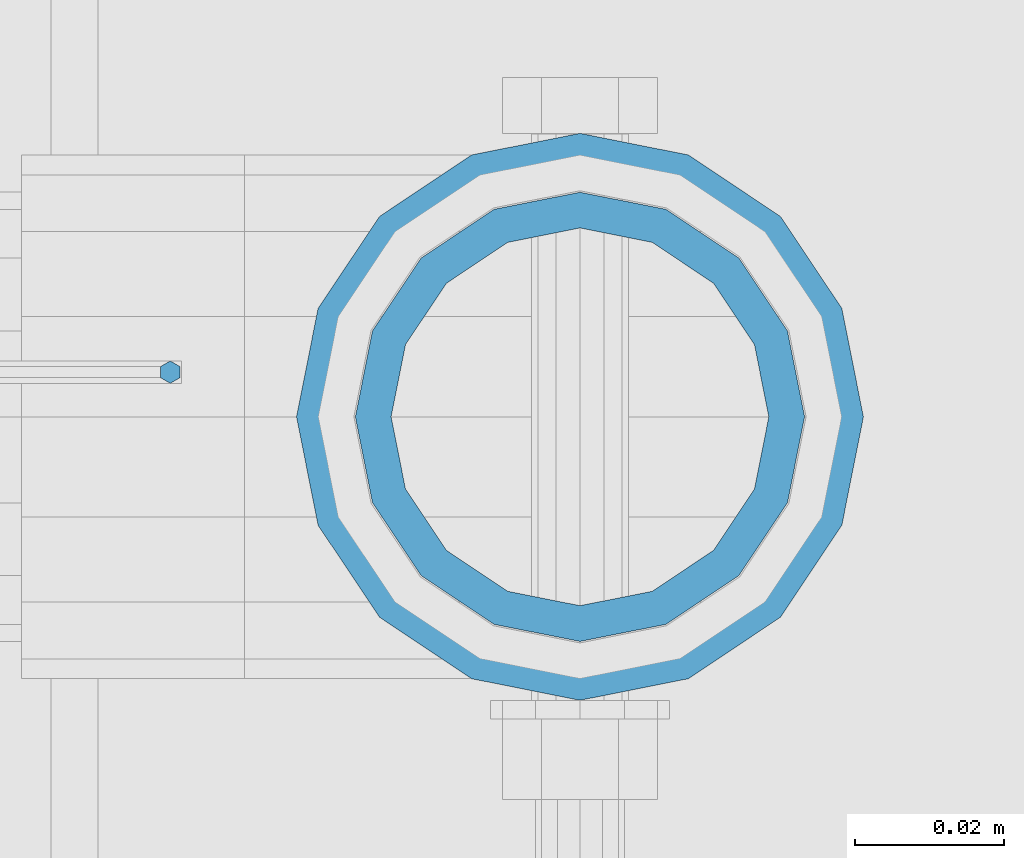
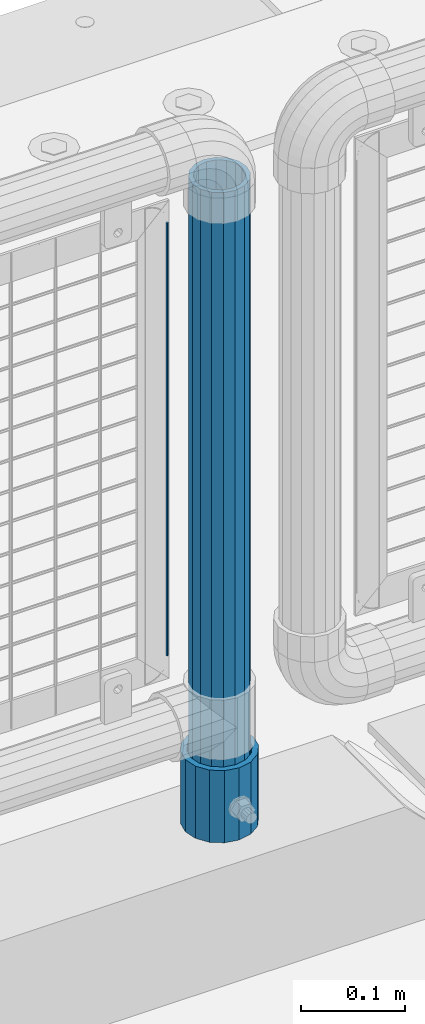
# One storey, part 85 of 208: 3 columns.
"""IFC2X3 building model written with IfcOpenShell, lengths in millimetres."""

from ifc_helpers import new_model, si_unit, frame, origin_with_axes, place, context, subcontext, project, spatial, faceted_brep, material, type_object, element, save


model = new_model("IFC2X3")

# Units and contexts
model_context = context("Model", 3, precision=1e-05, world=origin_with_axes())
body_context = subcontext(model_context, "Body", "Model", "MODEL_VIEW")
ifc_project = project(units=[si_unit("LENGTHUNIT", "METRE", prefix="MILLI"), si_unit("AREAUNIT", "SQUARE_METRE"), si_unit("VOLUMEUNIT", "CUBIC_METRE"), si_unit("MASSUNIT", "GRAM", prefix="KILO"), si_unit("TIMEUNIT", "SECOND"), si_unit("PLANEANGLEUNIT", "RADIAN"), si_unit("SOLIDANGLEUNIT", "STERADIAN"), si_unit("THERMODYNAMICTEMPERATUREUNIT", "DEGREE_CELSIUS"), si_unit("LUMINOUSINTENSITYUNIT", "LUMEN")], contexts=[model_context])

# Site, building, storey
site_placement = place(None, origin_with_axes())
site = spatial("IfcSite", under=ifc_project, at=site_placement, CompositionType="ELEMENT")
building_placement = place(site_placement, origin_with_axes())
building = spatial("IfcBuilding", under=site, at=building_placement, Name="Standard", CompositionType="ELEMENT")
storey_placement = place(building_placement, origin_with_axes())
storey = spatial("IfcBuildingStorey", under=building, at=storey_placement, Name="Undefined", CompositionType="ELEMENT", Elevation=0.0)

# Columns
ifc_material_1 = material()
column_type_1 = type_object("IfcColumnType", PredefinedType="NOTDEFINED")
column_1_placement = place(storey_placement, frame((-27429.0000001958, 4664.5, 168.019999999998), z_axis=(0.0, 1.0, 0.0), x_axis=(0.0, 0.0, 1.0)))
element("IfcColumn", 1, at=column_1_placement, inside=storey, type_object=column_type_1, material=ifc_material_1, context=body_context, shape_type="Brep", body=[
    faceted_brep([(0.0, -31.75, 0.0), (0.0, -29.3331751572332, 12.1501989775916), (85.0, -29.3331751572332, 12.1501989775916), (85.0, -31.75, 0.0), (0.0, -22.4506403026717, 22.4506403026726), (85.0, -22.4506403026717, 22.4506403026726), (0.0, -12.1501989775934, 29.3331751572332), (85.0, -12.1501989775934, 29.3331751572332), (0.0, 0.0, 31.75), (85.0, 0.0, 31.75), (0.0, 12.1501989775934, 29.3331751572332), (85.0, 12.1501989775934, 29.3331751572332), (0.0, 22.4506403026717, 22.4506403026726), (85.0, 22.4506403026717, 22.4506403026726), (0.0, 29.3331751572332, 12.1501989775916), (85.0, 29.3331751572332, 12.1501989775916), (0.0, 31.75, 0.0), (85.0, 31.75, 0.0), (0.0, 29.3331751572332, -12.1501989775916), (85.0, 29.3331751572332, -12.1501989775916), (0.0, 22.4506403026717, -22.4506403026726), (85.0, 22.4506403026717, -22.4506403026726), (0.0, 12.1501989775934, -29.3331751572332), (85.0, 12.1501989775934, -29.3331751572332), (0.0, 0.0, -31.75), (85.0, 0.0, -31.75), (0.0, -12.1501989775934, -29.3331751572332), (85.0, -12.1501989775934, -29.3331751572332), (0.0, -22.4506403026717, -22.4506403026726), (85.0, -22.4506403026717, -22.4506403026726), (0.0, -29.3331751572332, -12.1501989775916), (85.0, -29.3331751572332, -12.1501989775916), (0.0, -38.0499999999993, 0.0), (0.0, -35.1536162120537, -14.5611046014919), (85.0, -35.1536162120537, -14.5611046014919), (85.0, -38.0499999999993, 0.0), (0.0, -26.9054130241493, -26.9054130241484), (85.0, -26.9054130241493, -26.9054130241484), (0.0, -14.5611046014928, -35.1536162120547), (85.0, -14.5611046014928, -35.1536162120547), (0.0, 0.0, -38.0500000000002), (85.0, 0.0, -38.0500000000002), (0.0, 14.5611046014928, -35.1536162120547), (85.0, 14.5611046014928, -35.1536162120547), (0.0, 26.9054130241493, -26.9054130241484), (85.0, 26.9054130241493, -26.9054130241484), (0.0, 35.1536162120537, -14.5611046014919), (85.0, 35.1536162120537, -14.5611046014919), (0.0, 38.0499999999993, 0.0), (85.0, 38.0499999999993, 0.0), (0.0, 35.1536162120537, 14.5611046014919), (85.0, 35.1536162120537, 14.5611046014919), (0.0, 26.9054130241493, 26.9054130241484), (85.0, 26.9054130241493, 26.9054130241484), (0.0, 14.5611046014928, 35.1536162120547), (85.0, 14.5611046014928, 35.1536162120547), (0.0, 0.0, 38.0500000000002), (85.0, 0.0, 38.0500000000002), (0.0, -14.5611046014928, 35.1536162120547), (85.0, -14.5611046014928, 35.1536162120547), (0.0, -26.9054130241493, 26.9054130241484), (85.0, -26.9054130241493, 26.9054130241484), (0.0, -35.1536162120537, 14.5611046014919), (85.0, -35.1536162120537, 14.5611046014919)], [[[0, 1, 2, 3]], [[1, 4, 5, 2]], [[4, 6, 7, 5]], [[6, 8, 9, 7]], [[8, 10, 11, 9]], [[10, 12, 13, 11]], [[12, 14, 15, 13]], [[14, 16, 17, 15]], [[16, 18, 19, 17]], [[18, 20, 21, 19]], [[20, 22, 23, 21]], [[22, 24, 25, 23]], [[24, 26, 27, 25]], [[26, 28, 29, 27]], [[28, 30, 31, 29]], [[30, 0, 3, 31]], [[32, 33, 34, 35]], [[33, 36, 37, 34]], [[36, 38, 39, 37]], [[38, 40, 41, 39]], [[40, 42, 43, 41]], [[42, 44, 45, 43]], [[44, 46, 47, 45]], [[46, 48, 49, 47]], [[48, 50, 51, 49]], [[50, 52, 53, 51]], [[52, 54, 55, 53]], [[54, 56, 57, 55]], [[56, 58, 59, 57]], [[58, 60, 61, 59]], [[60, 62, 63, 61]], [[62, 32, 35, 63]], [[37, 39, 41, 43, 45, 47, 49, 51, 53, 55, 57, 59, 61, 63, 35, 34], [5, 7, 9, 11, 13, 15, 17, 19, 21, 23, 25, 27, 29, 31, 3, 2]], [[62, 60, 58, 56, 54, 52, 50, 48, 46, 44, 42, 40, 38, 36, 33, 32], [30, 28, 26, 24, 22, 20, 18, 16, 14, 12, 10, 8, 6, 4, 1, 0]]]),
])
column_type_2 = type_object("IfcColumnType", PredefinedType="NOTDEFINED")
column_2_placement = place(storey_placement, frame((-27429.0000001958, 4664.5, 168.019999999998), z_axis=(-1.0, 0.0, 0.0), x_axis=(0.0, 0.0, 1.0)))
element("IfcColumn", 2, at=column_2_placement, inside=storey, type_object=column_type_2, material=ifc_material_1, context=body_context, shape_type="Brep", body=[
    faceted_brep([(0.0, -25.3500000000004, 0.0), (0.0, -23.4203461491616, 9.70102501045403), (760.0, -23.4203461491616, 9.70102501045403), (760.0, -25.3500000000004, 0.0), (0.0, -17.9251569030794, 17.9251569030785), (760.0, -17.9251569030794, 17.9251569030785), (0.0, -9.70102501045494, 23.4203461491597), (760.0, -9.70102501045494, 23.4203461491597), (0.0, 0.0, 25.3499999999985), (760.0, 0.0, 25.3499999999985), (0.0, 9.70102501045494, 23.4203461491597), (760.0, 9.70102501045494, 23.4203461491597), (0.0, 17.9251569030794, 17.9251569030785), (760.0, 17.9251569030794, 17.9251569030785), (0.0, 23.4203461491616, 9.70102501045403), (760.0, 23.4203461491616, 9.70102501045403), (0.0, 25.3500000000004, 0.0), (760.0, 25.3500000000004, 0.0), (0.0, 23.4203461491616, -9.70102501045403), (760.0, 23.4203461491616, -9.70102501045403), (0.0, 17.9251569030794, -17.9251569030785), (760.0, 17.9251569030794, -17.9251569030785), (0.0, 9.70102501045494, -23.4203461491597), (760.0, 9.70102501045494, -23.4203461491597), (0.0, 0.0, -25.3499999999985), (760.0, 0.0, -25.3499999999985), (0.0, -9.70102501045494, -23.4203461491597), (760.0, -9.70102501045494, -23.4203461491597), (0.0, -17.9251569030794, -17.9251569030785), (760.0, -17.9251569030794, -17.9251569030785), (0.0, -23.4203461491616, -9.70102501045403), (760.0, -23.4203461491616, -9.70102501045403), (0.0, -30.1499999999996, 0.0), (0.0, -27.8549679052148, -11.5379054858058), (760.0, -27.8549679052148, -11.5379054858058), (760.0, -30.1499999999996, 0.0), (0.0, -21.3192694527743, -21.3192694527752), (760.0, -21.3192694527743, -21.3192694527752), (0.0, -11.5379054858076, -27.8549679052157), (760.0, -11.5379054858076, -27.8549679052157), (0.0, 0.0, -30.1500000000015), (760.0, 0.0, -30.1500000000015), (0.0, 11.5379054858076, -27.8549679052157), (760.0, 11.5379054858076, -27.8549679052157), (0.0, 21.3192694527743, -21.3192694527752), (760.0, 21.3192694527743, -21.3192694527752), (0.0, 27.8549679052157, -11.5379054858058), (760.0, 27.8549679052157, -11.5379054858058), (0.0, 30.1499999999996, 0.0), (760.0, 30.1499999999996, 0.0), (0.0, 27.8549679052157, 11.5379054858058), (760.0, 27.8549679052157, 11.5379054858058), (0.0, 21.3192694527743, 21.3192694527752), (760.0, 21.3192694527743, 21.3192694527752), (0.0, 11.5379054858076, 27.8549679052157), (760.0, 11.5379054858076, 27.8549679052157), (0.0, 0.0, 30.1500000000015), (760.0, 0.0, 30.1500000000015), (0.0, -11.5379054858076, 27.8549679052157), (760.0, -11.5379054858076, 27.8549679052157), (0.0, -21.3192694527743, 21.3192694527752), (760.0, -21.3192694527743, 21.3192694527752), (0.0, -27.8549679052157, 11.5379054858058), (760.0, -27.8549679052157, 11.5379054858058)], [[[0, 1, 2, 3]], [[1, 4, 5, 2]], [[4, 6, 7, 5]], [[6, 8, 9, 7]], [[8, 10, 11, 9]], [[10, 12, 13, 11]], [[12, 14, 15, 13]], [[14, 16, 17, 15]], [[16, 18, 19, 17]], [[18, 20, 21, 19]], [[20, 22, 23, 21]], [[22, 24, 25, 23]], [[24, 26, 27, 25]], [[26, 28, 29, 27]], [[28, 30, 31, 29]], [[30, 0, 3, 31]], [[32, 33, 34, 35]], [[33, 36, 37, 34]], [[36, 38, 39, 37]], [[38, 40, 41, 39]], [[40, 42, 43, 41]], [[42, 44, 45, 43]], [[44, 46, 47, 45]], [[46, 48, 49, 47]], [[48, 50, 51, 49]], [[50, 52, 53, 51]], [[52, 54, 55, 53]], [[54, 56, 57, 55]], [[56, 58, 59, 57]], [[58, 60, 61, 59]], [[60, 62, 63, 61]], [[62, 32, 35, 63]], [[37, 39, 41, 43, 45, 47, 49, 51, 53, 55, 57, 59, 61, 63, 35, 34], [5, 7, 9, 11, 13, 15, 17, 19, 21, 23, 25, 27, 29, 31, 3, 2]], [[62, 60, 58, 56, 54, 52, 50, 48, 46, 44, 42, 40, 38, 36, 33, 32], [30, 28, 26, 24, 22, 20, 18, 16, 14, 12, 10, 8, 6, 4, 1, 0]]]),
])
ifc_material_2 = material(Name="Misc_Undefined")
column_type_3 = type_object("IfcColumnType", Name="D3", PredefinedType="NOTDEFINED")
column_3_placement = place(storey_placement, frame((-27484.0, 4670.50000000001, 378.020000000006), z_axis=(-1.0, 0.0, 0.0), x_axis=(0.0, 0.0, 1.0)))
element("IfcColumn", 3, at=column_3_placement, inside=storey, type_object=column_type_3, material=ifc_material_2, ObjectType="D3", context=body_context, shape_type="Brep", body=[
    faceted_brep([(0.0, -1.49999999999909, 3.63797880709171e-12), (-7.27595761418343e-12, -0.749999999999091, -1.29903810567669), (510.0, -0.75, -1.29903810567703), (510.0, -1.5, 0.0), (-3.63797880709171e-12, 0.750000000000909, -1.29903810567669), (510.0, 0.75, -1.29903810567703), (0.0, 1.50000000000182, 3.63797880709171e-12), (510.0, 1.5, 0.0), (-3.63797880709171e-12, 0.750000000000909, 1.29903810567669), (510.0, 0.75, 1.29903810567703), (-7.27595761418343e-12, -0.749999999999091, 1.29903810567669), (510.0, -0.75, 1.29903810567703)], [[[0, 1, 2, 3]], [[1, 4, 5, 2]], [[4, 6, 7, 5]], [[6, 8, 9, 7]], [[8, 10, 11, 9]], [[10, 0, 3, 11]], [[5, 7, 9, 11, 3, 2]], [[10, 8, 6, 4, 1, 0]]]),
])

save(model, "model.ifc")
